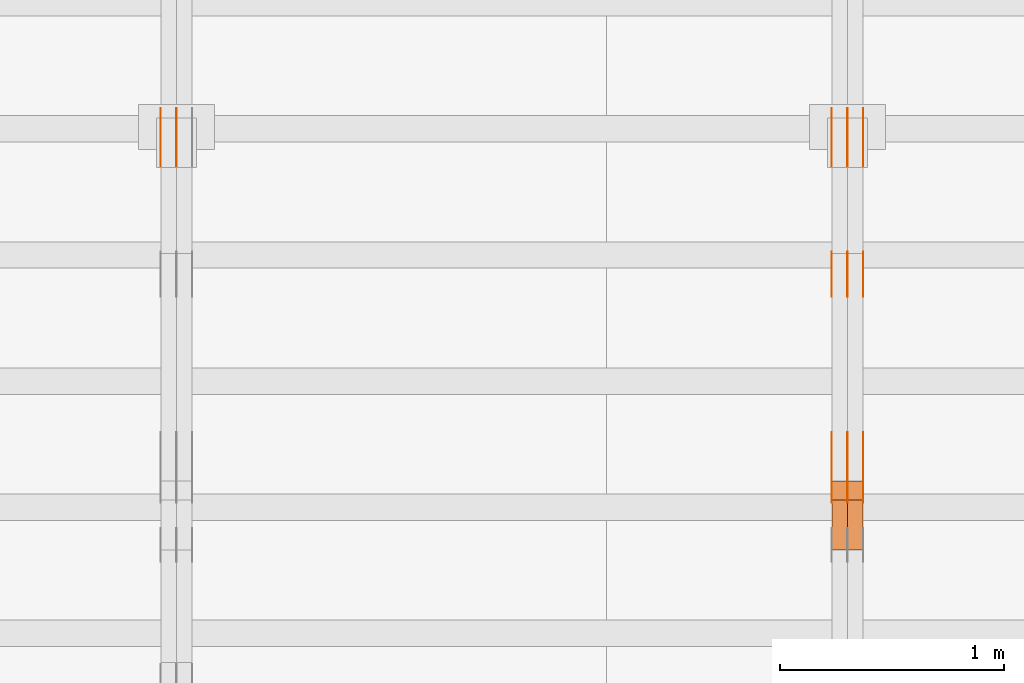
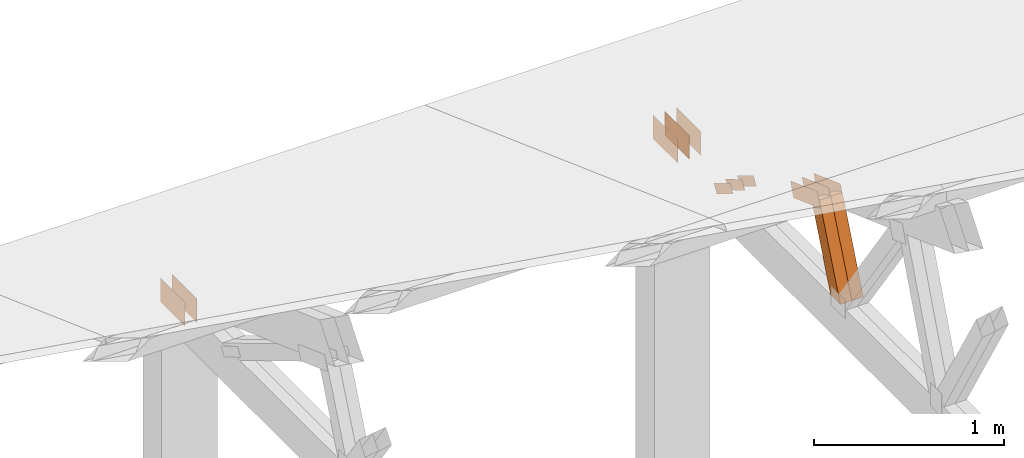
# One storey, part 118 of 189: 17 proxies.
"""IFC2X3 building model written with IfcOpenShell, lengths in millimetres."""

from ifc_helpers import new_model, entity, si_unit, converted_unit, derived_unit, direction, frame, origin, origin_2d_with_axis, place, context, subcontext, project, spatial, polyline, rectangle, outline, extrude, source, transform, mapped, material, type_object, type_shapes, element, save


model = new_model("IFC2X3")

# Units and contexts
model_context = context("Model", 3, precision=0.01, world=origin(), true_north=direction((6.12303176911189e-17, 1.0)))
body_context = subcontext(model_context, "Body", "Model", "MODEL_VIEW")
ifc_project = project(units=[si_unit("LENGTHUNIT", "METRE", prefix="MILLI"), si_unit("AREAUNIT", "SQUARE_METRE"), si_unit("VOLUMEUNIT", "CUBIC_METRE"), converted_unit("PLANEANGLEUNIT", "DEGREE", entity("IfcRatioMeasure", 0.0174532925199433), si_unit("PLANEANGLEUNIT", "RADIAN"), dimensions=[0, 0, 0, 0, 0, 0, 0]), si_unit("MASSUNIT", "GRAM", prefix="KILO"), derived_unit("MASSDENSITYUNIT", [(si_unit("MASSUNIT", "GRAM", prefix="KILO"), 1), (si_unit("LENGTHUNIT", "METRE"), -3)]), si_unit("TIMEUNIT", "SECOND"), si_unit("FREQUENCYUNIT", "HERTZ"), si_unit("THERMODYNAMICTEMPERATUREUNIT", "DEGREE_CELSIUS"), derived_unit("THERMALTRANSMITTANCEUNIT", [(si_unit("MASSUNIT", "GRAM", prefix="KILO"), 1), (si_unit("THERMODYNAMICTEMPERATUREUNIT", "KELVIN"), -1), (si_unit("TIMEUNIT", "SECOND"), -3)]), derived_unit("VOLUMETRICFLOWRATEUNIT", [(si_unit("LENGTHUNIT", "METRE"), 3), (si_unit("TIMEUNIT", "SECOND"), -1)]), si_unit("ELECTRICCURRENTUNIT", "AMPERE"), si_unit("ELECTRICVOLTAGEUNIT", "VOLT"), si_unit("POWERUNIT", "WATT"), si_unit("FORCEUNIT", "NEWTON"), si_unit("ILLUMINANCEUNIT", "LUX"), si_unit("LUMINOUSFLUXUNIT", "LUMEN"), si_unit("LUMINOUSINTENSITYUNIT", "CANDELA"), derived_unit("USERDEFINED", [(si_unit("MASSUNIT", "GRAM", prefix="KILO"), -1), (si_unit("LENGTHUNIT", "METRE"), -2), (si_unit("TIMEUNIT", "SECOND"), 3), (si_unit("LUMINOUSFLUXUNIT", "LUMEN"), 1)]), derived_unit("LINEARVELOCITYUNIT", [(si_unit("LENGTHUNIT", "METRE"), 1), (si_unit("TIMEUNIT", "SECOND"), -1)]), si_unit("PRESSUREUNIT", "PASCAL"), derived_unit("USERDEFINED", [(si_unit("LENGTHUNIT", "METRE"), -2), (si_unit("MASSUNIT", "GRAM", prefix="KILO"), 1), (si_unit("TIMEUNIT", "SECOND"), -2)])], contexts=[model_context])

# Site, building, storey
site_placement = place(None, origin())
site = spatial("IfcSite", under=ifc_project, at=site_placement, CompositionType="ELEMENT")
building_placement = place(site_placement, origin())
building = spatial("IfcBuilding", under=site, at=building_placement, CompositionType="ELEMENT")
storey_placement = place(building_placement, origin())
storey = spatial("IfcBuildingStorey", under=building, at=storey_placement, Name="Default", CompositionType="ELEMENT", Elevation=0.0)

# Proxies
ifc_material_1 = material(Name="IfcSurfaceStyle #72162")
building_element_proxy_type_1 = type_object("IfcBuildingElementProxyType", PredefinedType="NOTDEFINED", material=ifc_material_1)
shared_shape_1 = source(origin(), body_context, "Body", "SweptSolid", [
    extrude(outline(polyline([(-150.000004175486, -48.0000091256405), (150.000055794777, -48.0000091256405), (149.99999373786, 48.0000091256405), (-150.000045357151, 48.0000091256405), (-150.000004175486, -48.0000091256405)])), frame((150.000055794777, 48.0000091256405, 0.0), z_axis=(0.0, 0.0, 1.0), x_axis=(-1.0, 0.0, 0.0)), (0.0, 0.0, 1.0), 1.29999999999999),
])
type_shapes(building_element_proxy_type_1, [shared_shape_1])
proxy_1_placement = place(building_placement, frame((12301.3, 28002.7008500375, 633.16821439849), z_axis=(-1.0, 0.0, 0.0), x_axis=(0.0, -0.939692620785908, 0.342020143325669)))
element("IfcBuildingElementProxy", 1, at=proxy_1_placement, inside=storey, type_object=building_element_proxy_type_1, material=ifc_material_1, context=body_context, shape_type="MappedRepresentation", body=[
    mapped(shared_shape_1, transform((0.0, 0.0, 0.0), scale=1.0)),
])
ifc_material_2 = material(Name="IfcSurfaceStyle #72105")
building_element_proxy_type_2 = type_object("IfcBuildingElementProxyType", PredefinedType="NOTDEFINED", material=ifc_material_2)
shared_shape_2 = source(origin(), body_context, "Body", "SweptSolid", [
    extrude(outline(polyline([(-150.000004175486, -48.0000091256405), (150.000055794777, -48.0000091256405), (149.99999373786, 48.0000091256405), (-150.000045357151, 48.0000091256405), (-150.000004175486, -48.0000091256405)])), frame((150.000055794777, 48.0000091256405, 0.0), z_axis=(0.0, 0.0, 1.0), x_axis=(-1.0, 0.0, 0.0)), (0.0, 0.0, 1.0), 1.29999999999998),
])
type_shapes(building_element_proxy_type_2, [shared_shape_2])
proxy_2_placement = place(building_placement, frame((12230.0, 28002.7008500375, 633.16821439849), z_axis=(-1.0, 0.0, 0.0), x_axis=(0.0, -0.939692620785908, 0.342020143325669)))
element("IfcBuildingElementProxy", 2, at=proxy_2_placement, inside=storey, type_object=building_element_proxy_type_2, material=ifc_material_2, context=body_context, shape_type="MappedRepresentation", body=[
    mapped(shared_shape_2, transform((0.0, 0.0, 0.0), scale=1.0)),
])
ifc_material_3 = material(Name="IfcSurfaceStyle #72048")
building_element_proxy_type_3 = type_object("IfcBuildingElementProxyType", PredefinedType="NOTDEFINED", material=ifc_material_3)
shared_shape_3 = source(origin(), body_context, "Body", "SweptSolid", [
    extrude(outline(polyline([(-150.000004175486, -48.0000091256405), (150.000055794777, -48.0000091256405), (149.99999373786, 48.0000091256405), (-150.000045357151, 48.0000091256405), (-150.000004175486, -48.0000091256405)])), frame((150.000055794777, 48.0000091256405, 0.0), z_axis=(0.0, 0.0, 1.0), x_axis=(-1.0, 0.0, 0.0)), (0.0, 0.0, 1.0), 1.29999999999998),
])
type_shapes(building_element_proxy_type_3, [shared_shape_3])
proxy_3_placement = place(building_placement, frame((12231.3, 28002.7008500375, 633.16821439849), z_axis=(-1.0, 0.0, 0.0), x_axis=(0.0, -0.939692620785908, 0.342020143325669)))
element("IfcBuildingElementProxy", 3, at=proxy_3_placement, inside=storey, type_object=building_element_proxy_type_3, material=ifc_material_3, context=body_context, shape_type="MappedRepresentation", body=[
    mapped(shared_shape_3, transform((0.0, 0.0, 0.0), scale=1.0)),
])
ifc_material_4 = material(Name="IfcSurfaceStyle #71991")
building_element_proxy_type_4 = type_object("IfcBuildingElementProxyType", PredefinedType="NOTDEFINED", material=ifc_material_4)
shared_shape_4 = source(origin(), body_context, "Body", "SweptSolid", [
    extrude(outline(polyline([(-150.000004175486, -48.0000091256405), (150.000055794777, -48.0000091256405), (149.99999373786, 48.0000091256405), (-150.000045357151, 48.0000091256405), (-150.000004175486, -48.0000091256405)])), frame((150.000055794777, 48.0000091256405, 0.0), z_axis=(0.0, 0.0, 1.0), x_axis=(-1.0, 0.0, 0.0)), (0.0, 0.0, 1.0), 1.29999999999998),
])
type_shapes(building_element_proxy_type_4, [shared_shape_4])
proxy_4_placement = place(building_placement, frame((12160.0, 28002.7008500375, 633.16821439849), z_axis=(-1.0, 0.0, 0.0), x_axis=(0.0, -0.939692620785908, 0.342020143325669)))
element("IfcBuildingElementProxy", 4, at=proxy_4_placement, inside=storey, type_object=building_element_proxy_type_4, material=ifc_material_4, context=body_context, shape_type="MappedRepresentation", body=[
    mapped(shared_shape_4, transform((0.0, 0.0, 0.0), scale=1.0)),
])
ifc_material_5 = material(Name="IfcSurfaceStyle #71934")
building_element_proxy_type_5 = type_object("IfcBuildingElementProxyType", PredefinedType="NOTDEFINED", material=ifc_material_5)
shared_shape_5 = source(origin(), body_context, "Body", "SweptSolid", [
    extrude(outline(polyline([(-100.000014621824, -30.0000173081658), (100.000025679578, -30.0000173081658), (100.000010707989, 30.0000173081658), (-100.000021765743, 30.0000173081658), (-100.000014621824, -30.0000173081658)])), frame((100.000025679578, 30.0000173081658, 0.0), z_axis=(0.0, 0.0, 1.0), x_axis=(-1.0, 0.0, 0.0)), (0.0, 0.0, 1.0), 1.3),
])
type_shapes(building_element_proxy_type_5, [shared_shape_5])
proxy_5_placement = place(building_placement, frame((12301.3, 28812.2744732883, 167.948789809131), z_axis=(-1.0, 0.0, 0.0), x_axis=(0.0, -0.858392121304013, 0.51299411895576)))
element("IfcBuildingElementProxy", 5, at=proxy_5_placement, inside=storey, type_object=building_element_proxy_type_5, material=ifc_material_5, context=body_context, shape_type="MappedRepresentation", body=[
    mapped(shared_shape_5, transform((0.0, 0.0, 0.0), scale=1.0)),
])
ifc_material_6 = material(Name="IfcSurfaceStyle #71877")
building_element_proxy_type_6 = type_object("IfcBuildingElementProxyType", PredefinedType="NOTDEFINED", material=ifc_material_6)
shared_shape_6 = source(origin(), body_context, "Body", "SweptSolid", [
    extrude(outline(polyline([(-100.000014621824, -30.0000173081658), (100.000025679578, -30.0000173081658), (100.000010707989, 30.0000173081658), (-100.000021765743, 30.0000173081658), (-100.000014621824, -30.0000173081658)])), frame((100.000025679578, 30.0000173081658, 0.0), z_axis=(0.0, 0.0, 1.0), x_axis=(-1.0, 0.0, 0.0)), (0.0, 0.0, 1.0), 1.29999999999998),
])
type_shapes(building_element_proxy_type_6, [shared_shape_6])
proxy_6_placement = place(building_placement, frame((12230.0, 28812.2744732883, 167.948789809131), z_axis=(-1.0, 0.0, 0.0), x_axis=(0.0, -0.858392121304013, 0.51299411895576)))
element("IfcBuildingElementProxy", 6, at=proxy_6_placement, inside=storey, type_object=building_element_proxy_type_6, material=ifc_material_6, context=body_context, shape_type="MappedRepresentation", body=[
    mapped(shared_shape_6, transform((0.0, 0.0, 0.0), scale=1.0)),
])
ifc_material_7 = material(Name="IfcSurfaceStyle #71820")
building_element_proxy_type_7 = type_object("IfcBuildingElementProxyType", PredefinedType="NOTDEFINED", material=ifc_material_7)
shared_shape_7 = source(origin(), body_context, "Body", "SweptSolid", [
    extrude(outline(polyline([(-100.000014621824, -30.0000173081658), (100.000025679578, -30.0000173081658), (100.000010707989, 30.0000173081658), (-100.000021765743, 30.0000173081658), (-100.000014621824, -30.0000173081658)])), frame((100.000025679578, 30.0000173081658, 0.0), z_axis=(0.0, 0.0, 1.0), x_axis=(-1.0, 0.0, 0.0)), (0.0, 0.0, 1.0), 1.29999999999998),
])
type_shapes(building_element_proxy_type_7, [shared_shape_7])
proxy_7_placement = place(building_placement, frame((12231.3, 28812.2744732883, 167.948789809131), z_axis=(-1.0, 0.0, 0.0), x_axis=(0.0, -0.858392121304013, 0.51299411895576)))
element("IfcBuildingElementProxy", 7, at=proxy_7_placement, inside=storey, type_object=building_element_proxy_type_7, material=ifc_material_7, context=body_context, shape_type="MappedRepresentation", body=[
    mapped(shared_shape_7, transform((0.0, 0.0, 0.0), scale=1.0)),
])
ifc_material_8 = material(Name="IfcSurfaceStyle #71763")
building_element_proxy_type_8 = type_object("IfcBuildingElementProxyType", PredefinedType="NOTDEFINED", material=ifc_material_8)
shared_shape_8 = source(origin(), body_context, "Body", "SweptSolid", [
    extrude(outline(polyline([(-100.000014621824, -30.0000173081658), (100.000025679578, -30.0000173081658), (100.000010707989, 30.0000173081658), (-100.000021765743, 30.0000173081658), (-100.000014621824, -30.0000173081658)])), frame((100.000025679578, 30.0000173081658, 0.0), z_axis=(0.0, 0.0, 1.0), x_axis=(-1.0, 0.0, 0.0)), (0.0, 0.0, 1.0), 1.29999999999999),
])
type_shapes(building_element_proxy_type_8, [shared_shape_8])
proxy_8_placement = place(building_placement, frame((12160.0, 28812.2744732883, 167.948789809131), z_axis=(-1.0, 0.0, 0.0), x_axis=(0.0, -0.858392121304013, 0.51299411895576)))
element("IfcBuildingElementProxy", 8, at=proxy_8_placement, inside=storey, type_object=building_element_proxy_type_8, material=ifc_material_8, context=body_context, shape_type="MappedRepresentation", body=[
    mapped(shared_shape_8, transform((0.0, 0.0, 0.0), scale=1.0)),
])
ifc_material_9 = material(Name="IfcSurfaceStyle #71478")
building_element_proxy_type_9 = type_object("IfcBuildingElementProxyType", PredefinedType="NOTDEFINED", material=ifc_material_9)
shared_shape_9 = source(origin(), body_context, "Body", "SweptSolid", [
    extrude(rectangle(XDim=258.000001907349, YDim=151.999992370605, at=origin_2d_with_axis()), frame((129.000001782157, 75.9999961853027, 0.0), z_axis=(0.0, 0.0, 1.0), x_axis=(-1.0, 0.0, 0.0)), (0.0, 0.0, 1.0), 0.999999999999984),
])
type_shapes(building_element_proxy_type_9, [shared_shape_9])
proxy_9_placement = place(building_placement, frame((12301.0, 29483.7634609878, 116.138221740723), z_axis=(-1.0, 0.0, 0.0), x_axis=(0.0, -1.0, 0.0)))
element("IfcBuildingElementProxy", 9, at=proxy_9_placement, inside=storey, type_object=building_element_proxy_type_9, material=ifc_material_9, Name="GNT100S 152x258", context=body_context, shape_type="MappedRepresentation", body=[
    mapped(shared_shape_9, transform((0.0, 0.0, 0.0), scale=1.0)),
])
ifc_material_10 = material(Name="IfcSurfaceStyle #71421")
building_element_proxy_type_10 = type_object("IfcBuildingElementProxyType", PredefinedType="NOTDEFINED", material=ifc_material_10)
shared_shape_10 = source(origin(), body_context, "Body", "SweptSolid", [
    extrude(rectangle(XDim=258.000001907349, YDim=151.999992370605, at=origin_2d_with_axis()), frame((129.000001782157, 75.9999961853027, 0.0), z_axis=(0.0, 0.0, 1.0), x_axis=(-1.0, 0.0, 0.0)), (0.0, 0.0, 1.0), 0.999999999999984),
])
type_shapes(building_element_proxy_type_10, [shared_shape_10])
proxy_10_placement = place(building_placement, frame((12230.0, 29483.7634609878, 116.138221740723), z_axis=(-1.0, 0.0, 0.0), x_axis=(0.0, -1.0, 0.0)))
element("IfcBuildingElementProxy", 10, at=proxy_10_placement, inside=storey, type_object=building_element_proxy_type_10, material=ifc_material_10, Name="GNT100S 152x258", context=body_context, shape_type="MappedRepresentation", body=[
    mapped(shared_shape_10, transform((0.0, 0.0, 0.0), scale=1.0)),
])
ifc_material_11 = material(Name="IfcSurfaceStyle #71364")
building_element_proxy_type_11 = type_object("IfcBuildingElementProxyType", PredefinedType="NOTDEFINED", material=ifc_material_11)
shared_shape_11 = source(origin(), body_context, "Body", "SweptSolid", [
    extrude(rectangle(XDim=258.000001907349, YDim=151.999992370605, at=origin_2d_with_axis()), frame((129.000001782157, 75.9999961853027, 0.0), z_axis=(0.0, 0.0, 1.0), x_axis=(-1.0, 0.0, 0.0)), (0.0, 0.0, 1.0), 0.999999999999984),
])
type_shapes(building_element_proxy_type_11, [shared_shape_11])
proxy_11_placement = place(building_placement, frame((12231.0, 29483.7634609878, 116.138221740723), z_axis=(-1.0, 0.0, 0.0), x_axis=(0.0, -1.0, 0.0)))
element("IfcBuildingElementProxy", 11, at=proxy_11_placement, inside=storey, type_object=building_element_proxy_type_11, material=ifc_material_11, Name="GNT100S 152x258", context=body_context, shape_type="MappedRepresentation", body=[
    mapped(shared_shape_11, transform((0.0, 0.0, 0.0), scale=1.0)),
])
ifc_material_12 = material(Name="IfcSurfaceStyle #71307")
building_element_proxy_type_12 = type_object("IfcBuildingElementProxyType", PredefinedType="NOTDEFINED", material=ifc_material_12)
shared_shape_12 = source(origin(), body_context, "Body", "SweptSolid", [
    extrude(rectangle(XDim=258.000001907349, YDim=151.999992370605, at=origin_2d_with_axis()), frame((129.000001782157, 75.9999961853027, 0.0), z_axis=(0.0, 0.0, 1.0), x_axis=(-1.0, 0.0, 0.0)), (0.0, 0.0, 1.0), 0.999999999999984),
])
type_shapes(building_element_proxy_type_12, [shared_shape_12])
proxy_12_placement = place(building_placement, frame((12160.0, 29483.7634609878, 116.138221740723), z_axis=(-1.0, 0.0, 0.0), x_axis=(0.0, -1.0, 0.0)))
element("IfcBuildingElementProxy", 12, at=proxy_12_placement, inside=storey, type_object=building_element_proxy_type_12, material=ifc_material_12, Name="GNT100S 152x258", context=body_context, shape_type="MappedRepresentation", body=[
    mapped(shared_shape_12, transform((0.0, 0.0, 0.0), scale=1.0)),
])
ifc_material_13 = material(Name="IfcSurfaceStyle #65070")
building_element_proxy_type_13 = type_object("IfcBuildingElementProxyType", Name="T1-W15 65068", PredefinedType="NOTDEFINED", material=ifc_material_13)
shared_shape_13 = source(origin(), body_context, "Body", "SweptSolid", [
    extrude(outline(polyline([(-356.314733086722, -47.5000181042257), (225.500284389883, -47.5000181042257), (227.502094104438, -2.00397075419828e-05), (220.445344962296, 47.5000281240794), (-317.132990369895, 47.5000281240795), (-356.314733086722, -47.5000181042257)])), frame((227.502118521083, 47.5000281240794, 0.0), z_axis=(0.0, 0.0, 1.0), x_axis=(-1.0, 0.0, 0.0)), (0.0, 0.0, 1.0), 70.0),
])
type_shapes(building_element_proxy_type_13, [shared_shape_13])
proxy_13_placement = place(building_placement, frame((12300.0, 27820.3452927615, 748.492381554869), z_axis=(-1.0, 0.0, 0.0), x_axis=(0.0, -0.38128326679549, -0.9244582578255)))
element("IfcBuildingElementProxy", 13, at=proxy_13_placement, inside=storey, type_object=building_element_proxy_type_13, material=ifc_material_13, Name="T1-W15", context=body_context, shape_type="MappedRepresentation", body=[
    mapped(shared_shape_13, transform((0.0, 0.0, 0.0), scale=1.0)),
])
ifc_material_14 = material(Name="IfcSurfaceStyle #65004")
building_element_proxy_type_14 = type_object("IfcBuildingElementProxyType", Name="T1-W15 65002", PredefinedType="NOTDEFINED", material=ifc_material_14)
shared_shape_14 = source(origin(), body_context, "Body", "SweptSolid", [
    extrude(outline(polyline([(-356.314733086722, -47.5000181042257), (225.500284389883, -47.5000181042257), (227.502094104438, -2.00397075419828e-05), (220.445344962296, 47.5000281240794), (-317.132990369895, 47.5000281240795), (-356.314733086722, -47.5000181042257)])), frame((227.502118521083, 47.5000281240794, 0.0), z_axis=(0.0, 0.0, 1.0), x_axis=(-1.0, 0.0, 0.0)), (0.0, 0.0, 1.0), 70.0),
])
type_shapes(building_element_proxy_type_14, [shared_shape_14])
proxy_14_placement = place(building_placement, frame((12230.0, 27820.3452927615, 748.492381554869), z_axis=(-1.0, 0.0, 0.0), x_axis=(0.0, -0.38128326679549, -0.9244582578255)))
element("IfcBuildingElementProxy", 14, at=proxy_14_placement, inside=storey, type_object=building_element_proxy_type_14, material=ifc_material_14, Name="T1-W15", context=body_context, shape_type="MappedRepresentation", body=[
    mapped(shared_shape_14, transform((0.0, 0.0, 0.0), scale=1.0)),
])
ifc_material_15 = material(Name="IfcSurfaceStyle #55631")
building_element_proxy_type_15 = type_object("IfcBuildingElementProxyType", PredefinedType="NOTDEFINED", material=ifc_material_15)
shared_shape_15 = source(origin(), body_context, "Body", "SweptSolid", [
    extrude(rectangle(XDim=258.000001907349, YDim=151.999992370605, at=origin_2d_with_axis()), frame((129.000001782157, 75.9999961853027, 0.0), z_axis=(0.0, 0.0, 1.0), x_axis=(-1.0, 0.0, 0.0)), (0.0, 0.0, 1.0), 0.999999999999984),
])
type_shapes(building_element_proxy_type_15, [shared_shape_15])
proxy_15_placement = place(building_placement, frame((9230.0, 29483.7634609878, 116.138221740723), z_axis=(-1.0, 0.0, 0.0), x_axis=(0.0, -1.0, 0.0)))
element("IfcBuildingElementProxy", 15, at=proxy_15_placement, inside=storey, type_object=building_element_proxy_type_15, material=ifc_material_15, Name="GNT100S 152x258", context=body_context, shape_type="MappedRepresentation", body=[
    mapped(shared_shape_15, transform((0.0, 0.0, 0.0), scale=1.0)),
])
ifc_material_16 = material(Name="IfcSurfaceStyle #55574")
building_element_proxy_type_16 = type_object("IfcBuildingElementProxyType", PredefinedType="NOTDEFINED", material=ifc_material_16)
shared_shape_16 = source(origin(), body_context, "Body", "SweptSolid", [
    extrude(rectangle(XDim=258.000001907349, YDim=151.999992370605, at=origin_2d_with_axis()), frame((129.000001782157, 75.9999961853027, 0.0), z_axis=(0.0, 0.0, 1.0), x_axis=(-1.0, 0.0, 0.0)), (0.0, 0.0, 1.0), 0.999999999999984),
])
type_shapes(building_element_proxy_type_16, [shared_shape_16])
proxy_16_placement = place(building_placement, frame((9231.0, 29483.7634609878, 116.138221740723), z_axis=(-1.0, 0.0, 0.0), x_axis=(0.0, -1.0, 0.0)))
element("IfcBuildingElementProxy", 16, at=proxy_16_placement, inside=storey, type_object=building_element_proxy_type_16, material=ifc_material_16, Name="GNT100S 152x258", context=body_context, shape_type="MappedRepresentation", body=[
    mapped(shared_shape_16, transform((0.0, 0.0, 0.0), scale=1.0)),
])
ifc_material_17 = material(Name="IfcSurfaceStyle #55517")
building_element_proxy_type_17 = type_object("IfcBuildingElementProxyType", PredefinedType="NOTDEFINED", material=ifc_material_17)
shared_shape_17 = source(origin(), body_context, "Body", "SweptSolid", [
    extrude(rectangle(XDim=258.000001907349, YDim=151.999992370605, at=origin_2d_with_axis()), frame((129.000001782157, 75.9999961853027, 0.0), z_axis=(0.0, 0.0, 1.0), x_axis=(-1.0, 0.0, 0.0)), (0.0, 0.0, 1.0), 0.999999999999984),
])
type_shapes(building_element_proxy_type_17, [shared_shape_17])
proxy_17_placement = place(building_placement, frame((9160.0, 29483.7634609878, 116.138221740723), z_axis=(-1.0, 0.0, 0.0), x_axis=(0.0, -1.0, 0.0)))
element("IfcBuildingElementProxy", 17, at=proxy_17_placement, inside=storey, type_object=building_element_proxy_type_17, material=ifc_material_17, Name="GNT100S 152x258", context=body_context, shape_type="MappedRepresentation", body=[
    mapped(shared_shape_17, transform((0.0, 0.0, 0.0), scale=1.0)),
])

save(model, "model.ifc")
